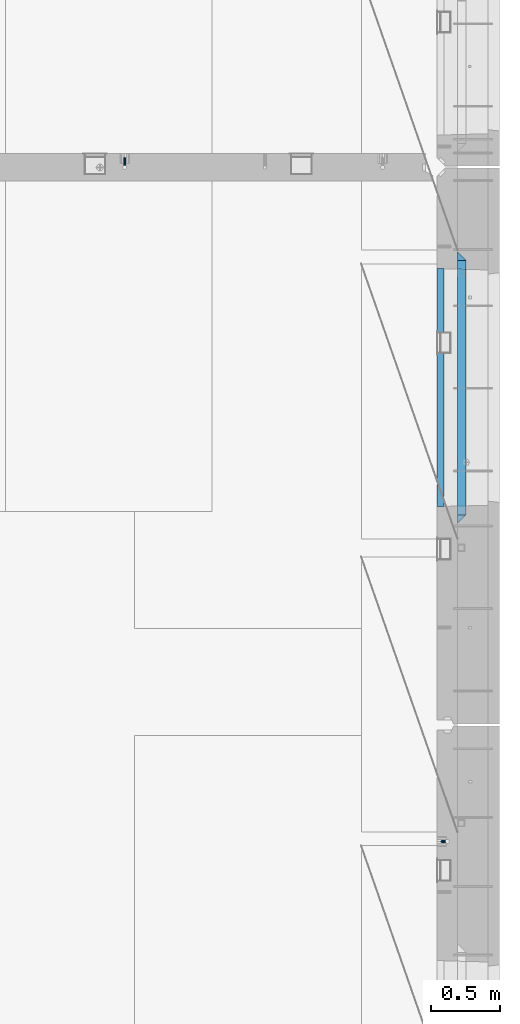
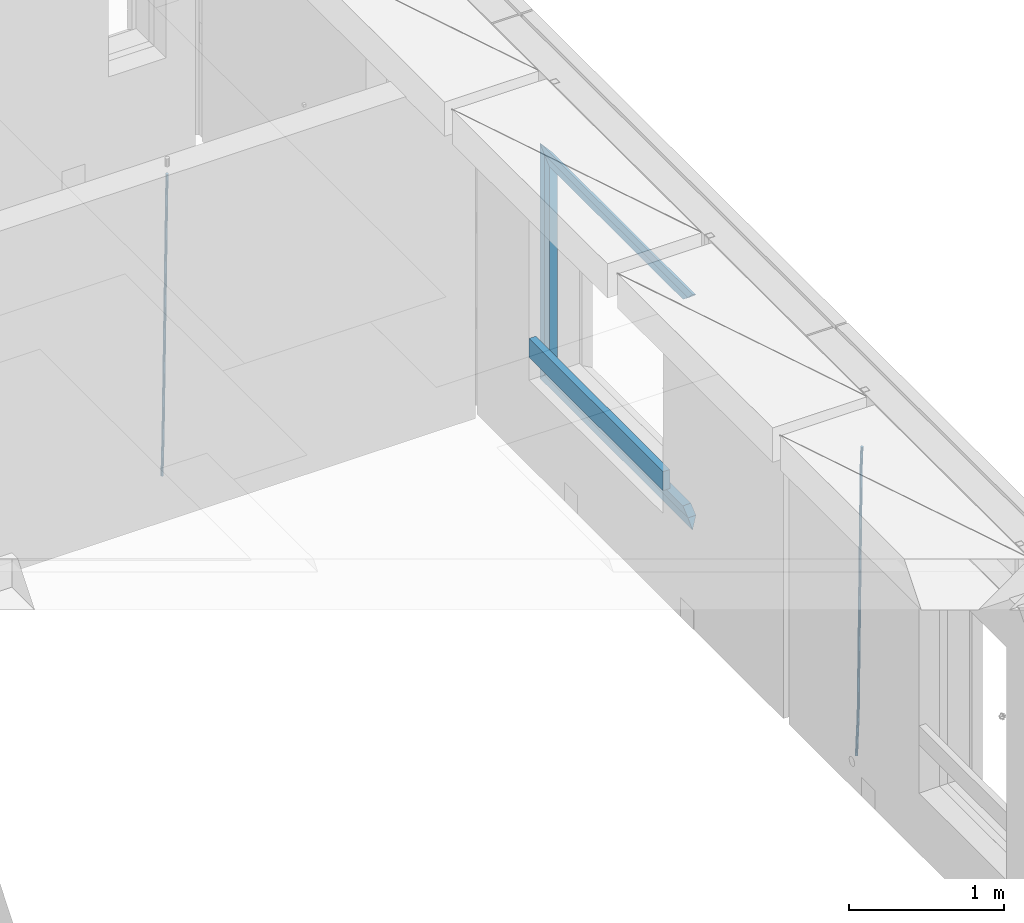
# One storey, part 131 of 352: 9 beams, 3 elements without a shape of their own.
"""IFC2X3 building model written with IfcOpenShell, lengths in millimetres."""

import ifcopenshell
import ifcopenshell.guid

model = None  # the IFC model being written
_history = None  # IfcOwnerHistory: only IFC2X3 demands one
_inside = {}  # id of a spatial element -> (the spatial element, [elements in it])
_under = {}  # id of a project, library or spatial element -> (it, [spatial elements below it])
_declared = {}  # id of a project -> (the project, [libraries it declares])
_typed = {}  # id of a type object -> (the type object, [elements of that type])
_made_of = {}  # id of a material, layer set ... -> (it, [elements and type objects made of it])


def new_model(schema):
    """Start an empty IFC model of exactly this schema.

    Asked for "IFC4X3", IfcOpenShell would pick the latest addendum, in which some entities
    have other attributes; the version numbers below select the first issue.
    IFC2X3 requires an IfcOwnerHistory on every rooted entity: one is made here for all.
    """
    global model, _history
    if schema == "IFC4X3":
        model = ifcopenshell.file(schema_version=(4, 3, 0, 0))
    else:
        model = ifcopenshell.file(schema=schema)
    _inside.clear()
    _under.clear()
    _declared.clear()
    _typed.clear()
    _made_of.clear()
    _history = None
    if model.schema == "IFC2X3":
        org = make("IfcOrganization", Name="unknown")
        user = make(
            "IfcPersonAndOrganization",
            ThePerson=make("IfcPerson", FamilyName="unknown"),
            TheOrganization=org,
        )
        app = make(
            "IfcApplication",
            ApplicationDeveloper=org,
            Version="unknown",
            ApplicationFullName="unknown",
            ApplicationIdentifier="unknown",
        )
        _history = make(
            "IfcOwnerHistory",
            OwningUser=user,
            OwningApplication=app,
            ChangeAction="ADDED",
            CreationDate=0,
        )
    return model


def make(cls, **values):
    """One entity of the class cls with the attributes given. An attribute that is None is left unset."""
    return model.create_entity(
        cls, **{name: value for name, value in values.items() if value is not None}
    )


def rooted(cls, **values):
    """An entity with a GlobalId (a new one), such as an element, a storey or a relation."""
    return make(cls, GlobalId=ifcopenshell.guid.new(), OwnerHistory=_history, **values)


def si_unit(unit_type, name, prefix=None):
    """IfcSIUnit, for example si_unit("LENGTHUNIT", "METRE", prefix="MILLI")."""
    return make("IfcSIUnit", UnitType=unit_type, Prefix=prefix, Name=name)


def assignment(units):
    """IfcUnitAssignment: the units of a project."""
    return None if units is None else make("IfcUnitAssignment", Units=units)


def point(xyz):
    """IfcCartesianPoint."""
    return None if xyz is None else make("IfcCartesianPoint", Coordinates=xyz)


def direction(xyz):
    """IfcDirection."""
    return None if xyz is None else make("IfcDirection", DirectionRatios=xyz)


def frame(location, z_axis=None, x_axis=None):
    """IfcAxis2Placement3D, a coordinate frame: its origin and axes. An axis left out is left unset."""
    return make(
        "IfcAxis2Placement3D",
        Location=point(location),
        Axis=direction(z_axis),
        RefDirection=direction(x_axis),
    )


def origin_with_axes():
    """The frame at (0, 0, 0) with the z axis (0, 0, 1) and the x axis (1, 0, 0) written out."""
    return frame((0.0, 0.0, 0.0), z_axis=(0.0, 0.0, 1.0), x_axis=(1.0, 0.0, 0.0))


def place(relative_to, where):
    """IfcLocalPlacement: puts the frame where relative to a parent placement (None: the world)."""
    return make(
        "IfcLocalPlacement", PlacementRelTo=relative_to, RelativePlacement=where
    )


def context(
    kind, dimensions, precision=None, world=None, true_north=None, identifier=None
):
    """IfcGeometricRepresentationContext, for example the 3D "Model" context."""
    return make(
        "IfcGeometricRepresentationContext",
        ContextIdentifier=identifier,
        ContextType=kind,
        CoordinateSpaceDimension=dimensions,
        Precision=precision,
        WorldCoordinateSystem=world,
        TrueNorth=true_north,
    )


def subcontext(parent, identifier, kind, view, scale=None):
    """IfcGeometricRepresentationSubContext, for example "Body" below "Model"."""
    return make(
        "IfcGeometricRepresentationSubContext",
        ContextIdentifier=identifier,
        ContextType=kind,
        ParentContext=parent,
        TargetScale=scale,
        TargetView=view,
    )


def project(units=None, contexts=None):
    """IfcProject with its units and contexts."""
    return rooted(
        "IfcProject",
        Name="project",
        RepresentationContexts=contexts,
        UnitsInContext=assignment(units),
    )


def spatial(cls, under=None, at=None, **own):
    """A site, building, storey or space (cls), placed at a placement, below another one or the project."""
    s = rooted(cls, ObjectPlacement=at, **own)
    if under is not None:
        _under.setdefault(under.id(), (under, []))[1].append(s)
    return s


def faces_of(points, faces, orient=None, outer=None):
    """IfcFace entities. A face is a list of loops; a loop is a list of indices into points, from 0.

    orient and outer hold one flag for each loop. By default every Orientation is true, the
    first loop of a face is its IfcFaceOuterBound and the others are IfcFaceBound.
    """
    made = []
    for i, loops in enumerate(faces):
        bounds = []
        for j, loop in enumerate(loops):
            is_outer = j == 0 if outer is None else outer[i][j]
            bounds.append(
                make(
                    "IfcFaceOuterBound" if is_outer else "IfcFaceBound",
                    Bound=make("IfcPolyLoop", Polygon=[points[k] for k in loop]),
                    Orientation=True if orient is None else orient[i][j],
                )
            )
        made.append(make("IfcFace", Bounds=bounds))
    return made


def faceted_brep(points, faces, orient=None, outer=None, voids=None):
    """IfcFacetedBrep: a solid bounded by flat faces; with voids (closed shells), ...WithVoids."""
    shared = [point(p) for p in points]
    hull = make("IfcClosedShell", CfsFaces=faces_of(shared, faces, orient, outer))
    if voids is None:
        return make("IfcFacetedBrep", Outer=hull)
    return make(
        "IfcFacetedBrepWithVoids",
        Outer=hull,
        Voids=[
            make(cls, CfsFaces=faces_of(shared, fs, o, b)) for cls, fs, o, b in voids
        ],
    )


def shape(context_of_items, identifier, shape_type, items):
    """IfcShapeRepresentation: the items that make up one representation, for example the "Body"."""
    return make(
        "IfcShapeRepresentation",
        ContextOfItems=context_of_items,
        RepresentationIdentifier=identifier,
        RepresentationType=shape_type,
        Items=items,
    )


def material(Name=None, Category=None):
    """IfcMaterial."""
    return make("IfcMaterial", Name=Name, Category=Category)


def made_of(thing, what):
    """Note that an element or type object is made of a material, layer set ...; save() writes the relation."""
    if what is not None:
        _made_of.setdefault(what.id(), (what, []))[1].append(thing)
    return thing


def type_object(cls, material=None, **own):
    """A type object (cls), such as IfcWallType, which elements share."""
    return made_of(rooted(cls, **own), material)


def element(
    cls,
    number,
    at=None,
    inside=None,
    cuts=None,
    type_object=None,
    material=None,
    context=None,
    identifier="Body",
    shape_type=None,
    held_by="IfcProductDefinitionShape",
    body=None,
    shapes=None,
    **own,
):
    """One element of the class cls, such as IfcWall. Its Tag is "e" and its number.

    at: its placement. inside: the storey or other place that contains it. cuts: it is an
    opening in that element (IfcRelVoidsElement). A single representation is given by context,
    identifier, shape_type and body (its items); several are given by shapes. held_by: the class
    of the entity that holds the representations. save() writes the other relations.
    """
    e = rooted(cls, Tag="e%d" % number, ObjectPlacement=at, **own)
    if body is not None:
        shapes = [shape(context, identifier, shape_type, body)]
    if shapes is not None:
        e.Representation = make(held_by, Representations=shapes)
    if inside is not None:
        _inside.setdefault(inside.id(), (inside, []))[1].append(e)
    if cuts is not None:
        rooted(
            "IfcRelVoidsElement", RelatingBuildingElement=cuts, RelatedOpeningElement=e
        )
    if type_object is not None:
        _typed.setdefault(type_object.id(), (type_object, []))[1].append(e)
    return made_of(e, material)


def aggregate(whole, parts):
    """IfcRelAggregates: a whole, such as a stair, and the parts it consists of."""
    return rooted("IfcRelAggregates", RelatingObject=whole, RelatedObjects=parts)


def save(model, path):
    """Write the relations noted so far, then the file.

    IfcRelAggregates (storeys below a building ...), IfcRelContainedInSpatialStructure (elements
    in a storey), IfcRelDefinesByType, IfcRelAssociatesMaterial and IfcRelDeclares: one each for
    every whole, place, type object, material and project.
    """
    for whole, parts in _under.values():
        aggregate(whole, parts)
    for where, things in _inside.values():
        rooted(
            "IfcRelContainedInSpatialStructure",
            RelatedElements=things,
            RelatingStructure=where,
        )
    for kind, things in _typed.values():
        rooted("IfcRelDefinesByType", RelatedObjects=things, RelatingType=kind)
    for what, things in _made_of.values():
        rooted("IfcRelAssociatesMaterial", RelatedObjects=things, RelatingMaterial=what)
    for by, libraries in _declared.values():
        rooted("IfcRelDeclares", RelatingContext=by, RelatedDefinitions=libraries)
    model.write(path)


model = new_model("IFC2X3")

# Units and contexts
model_context = context("Model", 3, precision=1e-05, world=origin_with_axes())
body_context = subcontext(model_context, "Body", "Model", "MODEL_VIEW")
ifc_project = project(units=[si_unit("LENGTHUNIT", "METRE", prefix="MILLI"), si_unit("AREAUNIT", "SQUARE_METRE"), si_unit("VOLUMEUNIT", "CUBIC_METRE"), si_unit("MASSUNIT", "GRAM", prefix="KILO"), si_unit("TIMEUNIT", "SECOND"), si_unit("PLANEANGLEUNIT", "RADIAN"), si_unit("SOLIDANGLEUNIT", "STERADIAN"), si_unit("THERMODYNAMICTEMPERATUREUNIT", "DEGREE_CELSIUS"), si_unit("LUMINOUSINTENSITYUNIT", "LUMEN")], contexts=[model_context])

# Site, building, storey
site_placement = place(None, origin_with_axes())
site = spatial("IfcSite", under=ifc_project, at=site_placement, CompositionType="ELEMENT")
building_placement = place(site_placement, origin_with_axes())
building = spatial("IfcBuilding", under=site, at=building_placement, CompositionType="ELEMENT")
storey_placement = place(building_placement, origin_with_axes())
storey = spatial("IfcBuildingStorey", under=building, at=storey_placement, Name="6", CompositionType="ELEMENT", Elevation=0.0)

# Assembly, beam
assembly_1_placement = place(storey_placement, origin_with_axes())
assembly_1 = element("IfcElementAssembly", 1, at=assembly_1_placement, inside=storey, AssemblyPlace="NOTDEFINED", PredefinedType="REINFORCEMENT_UNIT")
ifc_material_1 = material()
beam_type_1 = type_object("IfcBeamType", Name="D20", PredefinedType="NOTDEFINED")
beam_1_placement = place(assembly_1_placement, frame((32639.9999999961, 17044.9997581385, 96990.0), z_axis=(0.00020576299992186, -0.999642804629538, -0.0267249099901004), x_axis=(-4.30000201928125e-08, -0.0267249099948059, 0.999642825806181)))
beam_1 = element("IfcBeam", 2, at=beam_1_placement, type_object=beam_type_1, material=ifc_material_1, Name="JM20", ObjectType="D20", context=body_context, shape_type="Brep", body=[
    faceted_brep([(0.0, -10.0, 0.0), (-4.19531716033816e-08, -7.07106781186667, -7.07106781187031), (60.4266690400545, -7.0710677960451, -7.07106780570757), (60.4266690441291, -9.99999998418934, 6.15546014159918e-09), (0.0, 0.0, -10.0), (60.426669036824, 1.58106558956206e-08, -9.99999999384454), (4.196772351861e-08, 7.07106781186303, -7.07106781186667), (60.4266690363438, 7.07106782768096, -7.07106780570757), (0.0, 10.0, 0.0), (60.4266690388904, 10.0000000158179, 6.15182216279209e-09), (4.196772351861e-08, 7.07106781185939, 7.07106781185939), (60.4266690429649, 7.07106782768096, 7.07106781802577), (0.0, 0.0, 10.0), (60.4266690461809, 1.58179318532348e-08, 10.0000000061555), (-4.19531716033816e-08, -7.07106781187031, 7.07106781185939), (60.4266690466611, -7.07106779605238, 7.07106781802213), (61.0378400410118, -7.07106779588503, -7.07106780564936), (60.991799419251, -9.99999998403655, 6.21366780251265e-09), (61.0569027789461, 1.5985278878361e-08, -9.99999999378269), (61.0378209396877, 7.07106782784831, -7.07106780564936), (60.9917724058905, 10.0000000159635, 6.21366780251265e-09), (60.9457317841297, 7.07106782781193, 7.0710678180767), (60.9266690461809, 1.59488990902901e-08, 10.0000000062028), (60.9457508854539, -7.07106779591413, 7.0710678180767), (61.6489592143771, -7.07106614513759, -7.06310863441468), (61.5568818710308, -9.9999984576425, 0.00735959856683621), (61.6870830769039, 1.71821739058942e-06, -9.99179257185824), (61.6489210170112, 7.07106947854481, -7.06310888312146), (61.556827851804, 10.0000015422847, 0.00735924683976918), (61.4647505084577, 7.07106922979438, 7.07782747982128), (61.4266266459163, 1.36643211590126e-06, 10.0065114172685), (61.464788705809, -7.07106639389531, 7.07782772852806), (176.543135720174, -7.07075579406956, -5.56673531796696), (176.451058376813, -9.99968810657447, 1.50373291501455), (176.581259582701, 0.000312069292704109, -8.49541925541052), (176.543097522794, 7.07137982961285, -5.56673556667374), (176.451004357587, 10.00031189336, 1.50373256329476), (176.35892701424, 7.07137958085514, 8.57420079627263), (176.320803151699, 0.000311717507429421, 11.5028847337162), (176.358965211621, -7.07075604281999, 8.57420104497578), (177.098753836006, -7.07075429323595, -5.55949898843028), (176.98362511232, -9.99968666800123, 1.510669025065), (177.146421932586, 0.000313595905026887, -8.48805862247536), (177.098706077581, 7.07138133041735, -5.55949936166144), (176.983557571715, 10.0003133318824, 1.51066849724157), (176.868428848029, 7.07138095712435, 8.58083651073321), (176.820760751449, 0.000313067976094317, 11.5093961447819), (176.868476606425, -7.07075466652896, 8.58083688396073), (177.654312950661, -7.07075204110879, -5.54863964998367), (177.516135294456, -9.99968450931192, 1.52107783331303), (177.711524267797, 0.000315886711177882, -8.47701274570863), (177.654255632195, 7.07138358250813, -5.54864021007961), (177.516054233929, 10.0003154905207, 1.5210770412159), (177.377876577739, 7.0713830223176, 8.59079452451624), (177.320665260588, 0.000315094497636892, 11.5191676202448), (177.377933896176, -7.07075260129932, 8.59079508461218), (299.499456785634, -7.07025810522464, -3.16697112782276), (299.361279129444, -9.99919057342777, 3.90274635547394), (299.556668102785, 0.000809822595329024, -6.09534422354773), (299.499399467197, 7.07187751838501, -3.1669716879187), (299.361198068917, 10.0008094264049, 3.90274556338045), (299.223020412712, 7.07187695819448, 10.9724630466735), (299.165809095575, 0.000809030381788034, 13.9008361423985), (299.223077731163, -7.07025866542244, 10.9724636067695), (300.03174732349, -7.07025594743027, -3.15656661289177), (299.971788958996, -9.99918809853989, 3.91467979818117), (300.056572611924, 0.000811849109595641, -6.08557274808481), (300.031722507032, 7.07187967631762, -3.15656653768019), (299.971753863239, 10.0008119014747, 3.91467990454839), (299.91179549876, 7.07187975035777, 10.9859263156177), (299.886970210311, 0.000811953817901667, 13.9149324508144), (299.911820315203, -7.0702558733974, 10.9859262404061), (300.564137759997, -7.07025623699155, -3.15794273276697), (300.582413367199, -9.99918843065097, 3.91310145956595), (300.556570941641, 0.000811577163403854, -6.0868651410201), (300.564145451674, 7.07187938674906, -3.15794274158179), (300.582424244858, 10.0008115693345, 3.91310144710224), (300.600699852032, 7.07187937566778, 10.9841456394352), (300.608266670402, 0.000811561512819026, 13.9130680476919), (300.600692160384, -7.07025624805829, 10.98414564825), (2294.16589219622, -7.0713405251372, -8.31099358700158), (2294.1841678034, -10.0002727187966, -1.23994939466866), (2294.15832537785, -0.000272710982244462, -11.2399159952547), (2294.16589988787, 7.07079509858886, -8.31099359582004), (2294.18417868105, 9.99972728118883, -1.23994940713601), (2294.20245428824, 7.07079508752213, 5.83109478519327), (2294.2100211066, -0.00027272663282929, 8.76001719345368), (2294.20244659658, -7.07134053620393, 5.83109479401173), (2294.7782683276, -7.07134085819416, -8.31257645345977), (2294.72126025338, -10.000273010919, -1.24133766827799), (2294.84007459224, -0.000273081772320438, -11.2416781768807), (2294.87047377572, 7.07079471537872, -8.31281477453012), (2294.85165844864, 9.9997269181622, -1.24167470516841), (2294.7946503744, 7.07079476544459, 5.82956408001337), (2294.73284410976, -0.000273010977252852, 8.75866580342336), (2294.7024449263, -7.07134080815013, 5.82980240107645), (2295.39054023061, -7.0793250091956, -8.30442771922026), (2295.25826128852, -10.0072756143927, -1.23419071494573), (2295.52170777075, -0.00916171800054144, -11.2326063125765), (2295.57492774284, 7.06160849139269, -8.30343918807193), (2295.51902460904, 9.99102432676591, -1.23279272078435), (2295.38674566693, 7.06307372157607, 5.83744428349019), (2295.25557812679, -0.0070895696117077, 8.76562287684646), (2295.20235815471, -7.07785977901949, 5.83645575234186), (2317.1947101649, -7.36365585014573, -8.01423575520312), (2317.06243122277, -10.2916064553428, -0.94399875092131), (2317.32587770502, -0.293492558957951, -10.9424143485521), (2317.37909767711, 6.77727765044983, -8.01324722405116), (2317.32319454331, 9.70669348581578, -0.942600756767206), (2317.1909156012, 6.77874288063322, 6.12763624751096), (2317.05974806109, -0.291420410569117, 9.0558148408636), (2317.00652808898, -7.36219061996962, 6.12664771636264), (2317.83015404257, -7.37194216843636, -8.00577862486898), (2317.72252095213, -10.300214160583, -0.935213608652703), (2317.90419832576, -0.301033978277701, -10.9347174723516), (2317.90127966482, 6.77046829039318, -8.00629749759901), (2317.82310777172, 9.70017451494641, -0.935947405505431), (2317.71547468127, 6.77190252279979, 6.13461761071085), (2317.64143039809, -0.29900566735887, 9.06355645819713), (2317.64434905903, -7.37050793602975, 6.13513648344451), (2318.46565174212, -7.3700661537805, -7.99751648408346), (2318.38266643914, -10.2982456018653, -0.926623872735945), (2318.48256818345, -0.299336209594912, -10.9272153854981), (2318.42350634121, 6.77200652527245, -7.99954269419686), (2318.32306384158, 9.70166538090416, -0.929489366557391), (2318.2400785386, 6.77348593281204, 6.14140324480104), (2318.22316209726, -0.297244011366274, 9.07110214621207), (2318.2822239395, -7.36858674623363, 6.1434294549108), (2418.48643733139, -7.07180401323421, -6.70013846199799), (2418.4034520284, -9.99998346132634, 0.370754149349523), (2418.5033537727, -0.00107406904135132, -9.62983736341266), (2418.44429193046, 7.07026866581873, -6.70216467211139), (2418.34384943081, 9.99992752145772, 0.367888655531715), (2418.26086412782, 7.0717480733656, 7.43878126688651), (2418.24394768651, 0.00101812917273492, 10.3684801682975), (2418.30300952874, -7.07032460568735, 7.44080747699627)], [[[0, 1, 2, 3]], [[1, 4, 5, 2]], [[4, 6, 7, 5]], [[6, 8, 9, 7]], [[8, 10, 11, 9]], [[10, 12, 13, 11]], [[12, 14, 15, 13]], [[14, 0, 3, 15]], [[14, 12, 10, 8, 6, 4, 1, 0]], [[3, 2, 16, 17]], [[2, 5, 18, 16]], [[5, 7, 19, 18]], [[7, 9, 20, 19]], [[9, 11, 21, 20]], [[11, 13, 22, 21]], [[13, 15, 23, 22]], [[15, 3, 17, 23]], [[17, 16, 24, 25]], [[16, 18, 26, 24]], [[18, 19, 27, 26]], [[19, 20, 28, 27]], [[20, 21, 29, 28]], [[21, 22, 30, 29]], [[22, 23, 31, 30]], [[23, 17, 25, 31]], [[25, 24, 32, 33]], [[24, 26, 34, 32]], [[26, 27, 35, 34]], [[27, 28, 36, 35]], [[28, 29, 37, 36]], [[29, 30, 38, 37]], [[30, 31, 39, 38]], [[31, 25, 33, 39]], [[33, 32, 40, 41]], [[32, 34, 42, 40]], [[34, 35, 43, 42]], [[35, 36, 44, 43]], [[36, 37, 45, 44]], [[37, 38, 46, 45]], [[38, 39, 47, 46]], [[39, 33, 41, 47]], [[41, 40, 48, 49]], [[40, 42, 50, 48]], [[42, 43, 51, 50]], [[43, 44, 52, 51]], [[44, 45, 53, 52]], [[45, 46, 54, 53]], [[46, 47, 55, 54]], [[47, 41, 49, 55]], [[49, 48, 56, 57]], [[48, 50, 58, 56]], [[50, 51, 59, 58]], [[51, 52, 60, 59]], [[52, 53, 61, 60]], [[53, 54, 62, 61]], [[54, 55, 63, 62]], [[55, 49, 57, 63]], [[57, 56, 64, 65]], [[56, 58, 66, 64]], [[58, 59, 67, 66]], [[59, 60, 68, 67]], [[60, 61, 69, 68]], [[61, 62, 70, 69]], [[62, 63, 71, 70]], [[63, 57, 65, 71]], [[65, 64, 72, 73]], [[64, 66, 74, 72]], [[66, 67, 75, 74]], [[67, 68, 76, 75]], [[68, 69, 77, 76]], [[69, 70, 78, 77]], [[70, 71, 79, 78]], [[71, 65, 73, 79]], [[73, 72, 80, 81]], [[72, 74, 82, 80]], [[74, 75, 83, 82]], [[75, 76, 84, 83]], [[76, 77, 85, 84]], [[77, 78, 86, 85]], [[78, 79, 87, 86]], [[79, 73, 81, 87]], [[81, 80, 88, 89]], [[80, 82, 90, 88]], [[82, 83, 91, 90]], [[83, 84, 92, 91]], [[84, 85, 93, 92]], [[85, 86, 94, 93]], [[86, 87, 95, 94]], [[87, 81, 89, 95]], [[89, 88, 96, 97]], [[88, 90, 98, 96]], [[90, 91, 99, 98]], [[91, 92, 100, 99]], [[92, 93, 101, 100]], [[93, 94, 102, 101]], [[94, 95, 103, 102]], [[95, 89, 97, 103]], [[97, 96, 104, 105]], [[96, 98, 106, 104]], [[98, 99, 107, 106]], [[99, 100, 108, 107]], [[100, 101, 109, 108]], [[101, 102, 110, 109]], [[102, 103, 111, 110]], [[103, 97, 105, 111]], [[105, 104, 112, 113]], [[104, 106, 114, 112]], [[106, 107, 115, 114]], [[107, 108, 116, 115]], [[108, 109, 117, 116]], [[109, 110, 118, 117]], [[110, 111, 119, 118]], [[111, 105, 113, 119]], [[113, 112, 120, 121]], [[112, 114, 122, 120]], [[114, 115, 123, 122]], [[115, 116, 124, 123]], [[116, 117, 125, 124]], [[117, 118, 126, 125]], [[118, 119, 127, 126]], [[119, 113, 121, 127]], [[121, 120, 128, 129]], [[120, 122, 130, 128]], [[122, 123, 131, 130]], [[123, 124, 132, 131]], [[124, 125, 133, 132]], [[125, 126, 134, 133]], [[126, 127, 135, 134]], [[127, 121, 129, 135]], [[130, 131, 132, 133, 134, 135, 129, 128]]]),
])
aggregate(assembly_1, [beam_1])

assembly_2_placement = place(storey_placement, origin_with_axes())
assembly_2 = element("IfcElementAssembly", 3, at=assembly_2_placement, inside=storey, AssemblyPlace="NOTDEFINED", PredefinedType="REINFORCEMENT_UNIT")
beam_2_placement = place(assembly_2_placement, frame((34944.9999977209, 12080.9402860984, 96990.0), z_axis=(0.999642804629538, 0.000205762999925497, -0.0267249099901003), x_axis=(0.0267249109941254, -4.30000210532798e-08, 0.999642825779465)))
beam_2 = element("IfcBeam", 4, at=beam_2_placement, type_object=beam_type_1, material=ifc_material_1, Name="JM20", ObjectType="D20", context=body_context, shape_type="Brep", body=[
    faceted_brep([(0.0, -10.0, 0.0), (-4.19531716033816e-08, -7.07106781186667, -7.07106781187031), (60.4266690400545, -7.0710677960451, -7.07106780570757), (60.4266690441291, -9.99999998418934, 6.15546014159918e-09), (0.0, 0.0, -10.0), (60.426669036824, 1.58106558956206e-08, -9.99999999384454), (4.196772351861e-08, 7.07106781186303, -7.07106781186667), (60.4266690363438, 7.07106782768096, -7.07106780570757), (0.0, 10.0, 0.0), (60.4266690388904, 10.0000000158179, 6.15182216279209e-09), (4.196772351861e-08, 7.07106781185939, 7.07106781185939), (60.4266690429649, 7.07106782768096, 7.07106781802577), (0.0, 0.0, 10.0), (60.4266690461809, 1.58179318532348e-08, 10.0000000061555), (-4.19531716033816e-08, -7.07106781187031, 7.07106781185939), (60.4266690466611, -7.07106779605238, 7.07106781802213), (61.0378400410118, -7.07106779588503, -7.07106780564936), (60.991799419251, -9.99999998403655, 6.21366780251265e-09), (61.0569027789461, 1.5985278878361e-08, -9.99999999378269), (61.0378209396877, 7.07106782784831, -7.07106780564936), (60.9917724058905, 10.0000000159635, 6.21366780251265e-09), (60.9457317841297, 7.07106782781193, 7.0710678180767), (60.9266690461809, 1.59488990902901e-08, 10.0000000062028), (60.9457508854539, -7.07106779591413, 7.0710678180767), (61.6489592143771, -7.07106614513759, -7.06310863441468), (61.5568818710308, -9.9999984576425, 0.00735959856683621), (61.6870830769039, 1.71821739058942e-06, -9.99179257185824), (61.6489210170112, 7.07106947854481, -7.06310888312146), (61.556827851804, 10.0000015422847, 0.00735924683976918), (61.4647505084577, 7.07106922979438, 7.07782747982128), (61.4266266459163, 1.36643211590126e-06, 10.0065114172685), (61.464788705809, -7.07106639389531, 7.07782772852806), (176.543135720174, -7.07075579406956, -5.56673531796696), (176.451058376813, -9.99968810657447, 1.50373291501455), (176.581259582701, 0.000312069292704109, -8.49541925541052), (176.543097522794, 7.07137982961285, -5.56673556667374), (176.451004357587, 10.00031189336, 1.50373256329476), (176.35892701424, 7.07137958085514, 8.57420079627263), (176.320803151699, 0.000311717507429421, 11.5028847337162), (176.358965211621, -7.07075604281999, 8.57420104497578), (177.098753836006, -7.07075429323595, -5.55949898843028), (176.98362511232, -9.99968666800123, 1.510669025065), (177.146421932586, 0.000313595905026887, -8.48805862247536), (177.098706077581, 7.07138133041735, -5.55949936166144), (176.983557571715, 10.0003133318824, 1.51066849724157), (176.868428848029, 7.07138095712435, 8.58083651073321), (176.820760751449, 0.000313067976094317, 11.5093961447819), (176.868476606425, -7.07075466652896, 8.58083688396073), (177.654312950661, -7.07075204110879, -5.54863964998367), (177.516135294456, -9.99968450931192, 1.52107783331303), (177.711524267797, 0.000315886711177882, -8.47701274570863), (177.654255632195, 7.07138358250813, -5.54864021007961), (177.516054233929, 10.0003154905207, 1.5210770412159), (177.377876577739, 7.0713830223176, 8.59079452451624), (177.320665260588, 0.000315094497636892, 11.5191676202448), (177.377933896176, -7.07075260129932, 8.59079508461218), (299.436796249574, -7.07025836271714, -3.1681962331204), (299.298618593355, -9.99919083092027, 3.90152125031091), (299.494007566798, 0.000809565110102994, -6.09656932889993), (299.436738931283, 7.07187726089978, -3.16819679320906), (299.298537533061, 10.0008091689197, 3.90152045822106), (299.160359876842, 7.07187670072017, 10.9712379416487), (299.103148559603, 0.000808772889286047, 13.8996110374392), (299.160417195119, -7.07025892290039, 10.9712385017483), (299.98743051647, -7.07025613056248, -3.15743315966392), (299.971788958996, -9.99918809853989, 3.91467979818117), (299.993912075952, 0.000811591617093654, -6.08679785393178), (299.987423933868, 7.07187949325817, -3.1574327280432), (299.971753863239, 10.0008119014747, 3.91467990454839), (299.95611230444, 7.07187992653053, 10.9867922621015), (299.949630744944, 0.000812204350950196, 13.9161569563694), (299.956118887014, -7.07025569729012, 10.9867918304735), (300.538107039494, -7.07025785017686, -3.16575821840888), (300.644985195438, -9.99919020432935, 3.90450175465594), (300.493854948218, 0.000810030429420294, -6.09435592770024), (300.538151196495, 7.071877773491, -3.16575855385963), (300.645047642858, 10.0008097955724, 3.90450128024895), (300.751925798773, 7.07187744142357, 10.9747612533101), (300.796177890064, 0.000809560813650023, 13.9033589625978), (300.751881641787, -7.07025818224065, 10.9747615887682), (2293.36490490142, -7.07648090940347, -33.2930642912361), (2293.47178305736, -10.0054132635523, -26.2228043181785), (2293.32065281013, -0.00541302880083094, -36.2216620005347), (2293.36494905842, 7.06565471425711, -33.2930646266868), (2293.47184550477, 9.99458673634581, -26.2228047925819), (2293.57872366071, 7.06565438219332, -19.1525448195243), (2293.62297575199, -0.00541349841296324, -16.2239471102366), (2293.57867950371, -7.0764812414709, -19.1525444840736), (2294.0658245362, -7.07648309818615, -33.3036607065333), (2294.05312277409, -10.0054150789219, -26.2315929392535), (2294.10928714235, -0.00541549149056664, -36.2335844756526), (2294.15805078732, 7.06565223761572, -33.3050546393533), (2294.18355038921, 9.99458451388637, -26.2335642579346), (2294.17084862708, 7.06565253314329, -19.1614964906439), (2294.12738602093, -0.00541507354500936, -16.2315727215355), (2294.07862237596, -7.07648280265857, -19.1601025578348), (2294.76670261032, -7.08562269121467, -33.294332712383), (2294.63442802057, -10.0129954178956, -26.2238563411993), (2294.89787471293, -0.0156988342423574, -36.2230891548279), (2294.95110548967, 7.05531064255774, -33.2944998654275), (2294.89521307347, 9.98530428734011, -26.2240927312887), (2294.76293848372, 7.0579315606592, -19.1536163601049), (2294.63176638114, -0.0119922963167483, -16.2248599176673), (2294.57853560438, -7.08300177311321, -19.1534492070678), (2316.52657204497, -7.36937582653991, -33.0047303660212), (2316.39429745522, -10.2967485532172, -25.9342539948302), (2316.65774414754, -0.299451969567599, -35.9334868084661), (2316.7109749243, 6.7715575072325, -33.0048975190657), (2316.65508250811, 9.70155115201487, -25.9344903849269), (2316.52280791836, 6.7741784253376, -18.8640140137468), (2316.39163581574, -0.295745431634714, -15.9352575713092), (2316.33840503903, -7.36675490843481, -18.863846860706), (2317.16202064224, -7.37766220584308, -32.9962731735213), (2317.05438744847, -10.3053562613532, -25.9254688497131), (2317.23607125619, -0.306993473008333, -35.925789846493), (2317.23316144495, 6.76474808850253, -32.9979477328052), (2317.15499573652, 9.6950321815566, -25.9278370341635), (2317.04736254275, 6.7673381260538, -18.8570327103698), (2316.97331192881, -0.303330606784584, -15.9275160373909), (2316.97622174003, -7.37507216829545, -18.8553581510787), (2317.79752306276, -7.37578610372293, -32.9880110666527), (2317.71453320107, -10.3033876998124, -25.9168792378296), (2317.81444760226, -0.305295583297266, -35.918287695793), (2317.75539265381, 6.76628640723357, -32.9911928173897), (2317.65495180529, 9.69652304524061, -25.9213789128698), (2317.5719619436, 6.76892144914746, -18.8502470840467), (2317.55503740412, -0.301569071270933, -15.9199704549137), (2317.61409235255, -7.3731510618054, -18.847065333317), (2417.8183084176, -7.07752398473531, -31.6906369377139), (2417.73531855589, -10.0051255808248, -24.6195051088798), (2417.83523295709, -0.007033464313281, -34.6209135668432), (2417.77617800863, 7.06454852621755, -31.6938186884508), (2417.67573716014, 9.99478516423187, -24.6240047839383), (2417.59274729842, 7.06718356813872, -17.5528729551006), (2417.57582275895, -0.00330695228694822, -14.6225963259749), (2417.6348777074, -7.07488894281778, -17.5496912043673)], [[[0, 1, 2, 3]], [[1, 4, 5, 2]], [[4, 6, 7, 5]], [[6, 8, 9, 7]], [[8, 10, 11, 9]], [[10, 12, 13, 11]], [[12, 14, 15, 13]], [[14, 0, 3, 15]], [[14, 12, 10, 8, 6, 4, 1, 0]], [[3, 2, 16, 17]], [[2, 5, 18, 16]], [[5, 7, 19, 18]], [[7, 9, 20, 19]], [[9, 11, 21, 20]], [[11, 13, 22, 21]], [[13, 15, 23, 22]], [[15, 3, 17, 23]], [[17, 16, 24, 25]], [[16, 18, 26, 24]], [[18, 19, 27, 26]], [[19, 20, 28, 27]], [[20, 21, 29, 28]], [[21, 22, 30, 29]], [[22, 23, 31, 30]], [[23, 17, 25, 31]], [[25, 24, 32, 33]], [[24, 26, 34, 32]], [[26, 27, 35, 34]], [[27, 28, 36, 35]], [[28, 29, 37, 36]], [[29, 30, 38, 37]], [[30, 31, 39, 38]], [[31, 25, 33, 39]], [[33, 32, 40, 41]], [[32, 34, 42, 40]], [[34, 35, 43, 42]], [[35, 36, 44, 43]], [[36, 37, 45, 44]], [[37, 38, 46, 45]], [[38, 39, 47, 46]], [[39, 33, 41, 47]], [[41, 40, 48, 49]], [[40, 42, 50, 48]], [[42, 43, 51, 50]], [[43, 44, 52, 51]], [[44, 45, 53, 52]], [[45, 46, 54, 53]], [[46, 47, 55, 54]], [[47, 41, 49, 55]], [[49, 48, 56, 57]], [[48, 50, 58, 56]], [[50, 51, 59, 58]], [[51, 52, 60, 59]], [[52, 53, 61, 60]], [[53, 54, 62, 61]], [[54, 55, 63, 62]], [[55, 49, 57, 63]], [[57, 56, 64, 65]], [[56, 58, 66, 64]], [[58, 59, 67, 66]], [[59, 60, 68, 67]], [[60, 61, 69, 68]], [[61, 62, 70, 69]], [[62, 63, 71, 70]], [[63, 57, 65, 71]], [[65, 64, 72, 73]], [[64, 66, 74, 72]], [[66, 67, 75, 74]], [[67, 68, 76, 75]], [[68, 69, 77, 76]], [[69, 70, 78, 77]], [[70, 71, 79, 78]], [[71, 65, 73, 79]], [[73, 72, 80, 81]], [[72, 74, 82, 80]], [[74, 75, 83, 82]], [[75, 76, 84, 83]], [[76, 77, 85, 84]], [[77, 78, 86, 85]], [[78, 79, 87, 86]], [[79, 73, 81, 87]], [[81, 80, 88, 89]], [[80, 82, 90, 88]], [[82, 83, 91, 90]], [[83, 84, 92, 91]], [[84, 85, 93, 92]], [[85, 86, 94, 93]], [[86, 87, 95, 94]], [[87, 81, 89, 95]], [[89, 88, 96, 97]], [[88, 90, 98, 96]], [[90, 91, 99, 98]], [[91, 92, 100, 99]], [[92, 93, 101, 100]], [[93, 94, 102, 101]], [[94, 95, 103, 102]], [[95, 89, 97, 103]], [[97, 96, 104, 105]], [[96, 98, 106, 104]], [[98, 99, 107, 106]], [[99, 100, 108, 107]], [[100, 101, 109, 108]], [[101, 102, 110, 109]], [[102, 103, 111, 110]], [[103, 97, 105, 111]], [[105, 104, 112, 113]], [[104, 106, 114, 112]], [[106, 107, 115, 114]], [[107, 108, 116, 115]], [[108, 109, 117, 116]], [[109, 110, 118, 117]], [[110, 111, 119, 118]], [[111, 105, 113, 119]], [[113, 112, 120, 121]], [[112, 114, 122, 120]], [[114, 115, 123, 122]], [[115, 116, 124, 123]], [[116, 117, 125, 124]], [[117, 118, 126, 125]], [[118, 119, 127, 126]], [[119, 113, 121, 127]], [[121, 120, 128, 129]], [[120, 122, 130, 128]], [[122, 123, 131, 130]], [[123, 124, 132, 131]], [[124, 125, 133, 132]], [[125, 126, 134, 133]], [[126, 127, 135, 134]], [[127, 121, 129, 135]], [[130, 131, 132, 133, 134, 135, 129, 128]]]),
])
aggregate(assembly_2, [beam_2])

# Assembly, beams
assembly_3_placement = place(storey_placement, origin_with_axes())
assembly_3 = element("IfcElementAssembly", 5, at=assembly_3_placement, inside=storey, AssemblyPlace="NOTDEFINED", PredefinedType="REINFORCEMENT_UNIT")
ifc_material_2 = material(Name="TIMBER/T24")
beam_type_2 = type_object("IfcBeamType", PredefinedType="NOTDEFINED")
beam_3_placement = place(assembly_3_placement, frame((34935.0002758707, 14515.0011884524, 97685.0), z_axis=(0.0, 0.0, 1.0), x_axis=(0.0, 1.0, 0.0)))
beam_3 = element("IfcBeam", 6, at=beam_3_placement, type_object=beam_type_2, material=ifc_material_2, context=body_context, shape_type="Brep", body=[
    faceted_brep([(-3.63797880709171e-12, 24.9999999999964, -75.0), (-3.63797880709171e-12, 24.9999999999964, 75.0), (1730.0, 25.0, 75.0), (1730.0, 25.0, -75.0), (0.0, -25.0000000000073, 75.0), (1730.0, -25.0, 75.0), (0.0, -25.0000000000073, -75.0), (1730.0, -25.0, -75.0)], [[[0, 1, 2, 3]], [[1, 4, 5, 2]], [[4, 6, 7, 5]], [[6, 0, 3, 7]], [[5, 7, 3, 2]], [[6, 4, 1, 0]]]),
])
ifc_material_3 = material(Name="CONCRETE/C25/30")
beam_type_3 = type_object("IfcBeamType", PredefinedType="NOTDEFINED")
beam_4_placement = place(assembly_3_placement, frame((35090.0, 14394.9995850056, 99145.0), z_axis=(0.0, 0.0, -1.0), x_axis=(0.0, 1.0, 0.0)))
beam_4 = element("IfcBeam", 7, at=beam_4_placement, type_object=beam_type_3, material=ifc_material_3, Name="SK", context=body_context, shape_type="Brep", body=[
    faceted_brep([(60.0000000000073, 30.0, 30.0), (0.0, -30.0, -30.0), (60.0000000000073, -30.0, 30.0), (1910.00076293945, 30.0, 30.0), (1970.00076293945, -30.0, -30.0), (1910.00076293945, -30.0, 30.0)], [[[0, 1, 2]], [[1, 0, 3, 4]], [[2, 1, 4, 5]], [[0, 2, 5, 3]], [[4, 3, 5]]]),
])
beam_5_placement = place(assembly_3_placement, frame((35090.0, 14454.9995850056, 99085.0), z_axis=(0.0, 0.0, -1.0), x_axis=(0.0, 1.0, 0.0)))
beam_5 = element("IfcBeam", 8, at=beam_5_placement, type_object=beam_type_3, material=ifc_material_3, Name="SK", context=body_context, shape_type="Brep", body=[
    faceted_brep([(1785.9467088854, -30.0, 24.0540540540533), (1784.32508726378, 30.0, 25.6756756756804), (65.6764386151262, 30.0, 25.6756756756804), (64.0548169935064, -30.0, 24.0540540540533), (65.6764386151262, 30.0, 26.294090229203), (64.0548169935064, -30.0, 24.9041288395529), (0.0, 30.0, -30.0), (0.0, -30.0, -30.0), (1850.00076293945, 30.0, -30.0), (1850.00076293945, -30.0, -30.0), (1785.9467088854, -30.0, 24.9034748914128), (1784.32508726378, 30.0, 26.2934362810774)], [[[0, 1, 2, 3]], [[3, 2, 4, 5]], [[5, 4, 6, 7]], [[7, 6, 8, 9]], [[0, 3, 5, 7, 9, 10]], [[1, 0, 10, 11]], [[6, 4, 2, 1, 11, 8]], [[9, 8, 11, 10]]]),
])
beam_6_placement = place(assembly_3_placement, frame((35090.0, 16335.0003479451, 99175.0), z_axis=(0.0, -1.0, 0.0), x_axis=(0.0, 0.0, -1.0)))
beam_6 = element("IfcBeam", 9, at=beam_6_placement, type_object=beam_type_3, material=ifc_material_3, Name="SK", context=body_context, shape_type="Brep", body=[
    faceted_brep([(60.0000000000073, 30.0, 30.0), (0.0, -30.0, -30.0), (60.0000000000073, -30.0, 30.0), (1795.00000000001, 30.0, 30.0), (1855.0, -30.0, -30.0), (1795.00000000001, -30.0, 30.0)], [[[0, 1, 2]], [[3, 4, 1, 0]], [[4, 5, 2, 1]], [[5, 3, 0, 2]], [[5, 4, 3]]]),
])
beam_7_placement = place(assembly_3_placement, frame((35090.0, 16305.0003479451, 97410.0), z_axis=(0.0, 0.0, 1.0), x_axis=(0.0, -1.0, 0.0)))
beam_7 = element("IfcBeam", 10, at=beam_7_placement, type_object=beam_type_3, material=ifc_material_3, Name="SK", context=body_context, shape_type="Brep", body=[
    faceted_brep([(1785.94594594595, -30.0, 24.0540540540533), (1784.32432432433, 30.0, 25.6756756756804), (65.6756756756768, 30.0, 25.6756756756804), (64.0540540540533, -30.0, 24.0540540540533), (1785.94594594595, -30.0, 24.9041288395238), (1784.32432432433, 30.0, 26.2940902291739), (1850.00076293945, -30.0, -30.0), (1850.00076293945, 30.0, -30.0), (0.0, 30.0, -30.0), (65.6756756756768, 30.0, 26.293436281092), (64.0540540540533, -30.0, 24.9034748914419), (0.0, -30.0, -30.0)], [[[0, 1, 2, 3]], [[1, 0, 4, 5]], [[4, 6, 7, 5]], [[2, 1, 5, 7, 8, 9]], [[3, 2, 9, 10]], [[6, 4, 0, 3, 10, 11]], [[11, 8, 7, 6]], [[11, 10, 9, 8]]]),
])
beam_8_placement = place(assembly_3_placement, frame((35090.0, 16365.0003479451, 97350.0), z_axis=(0.0, 0.0, 1.0), x_axis=(0.0, -1.0, 0.0)))
beam_8 = element("IfcBeam", 11, at=beam_8_placement, type_object=beam_type_3, material=ifc_material_3, Name="SK", context=body_context, shape_type="Brep", body=[
    faceted_brep([(1970.00076293945, -30.0, -30.0), (1910.00076293945, 30.0, 30.0), (1910.00076293945, -30.0, 30.0), (60.0000000000073, 30.0, 30.0), (60.0000000000073, -30.0, 30.0), (0.0, -30.0, -30.0)], [[[0, 1, 2]], [[3, 4, 2, 1]], [[4, 5, 0, 2]], [[5, 3, 1, 0]], [[3, 5, 4]]]),
])
beam_type_4 = type_object("IfcBeamType", PredefinedType="NOTDEFINED")
beam_9_placement = place(assembly_3_placement, frame((35090.0, 16270.0003479451, 99115.0), z_axis=(0.0, -1.0, 0.0), x_axis=(0.0, 0.0, -1.0)))
beam_9 = element("IfcBeam", 12, at=beam_9_placement, type_object=beam_type_4, material=ifc_material_3, Name="SK", context=body_context, shape_type="Brep", body=[
    faceted_brep([(0.0, -30.0, -35.0), (54.9034748914273, -30.0, 29.0540540540533), (56.2934362811066, 30.0, 30.6756756756768), (0.0, 30.0, -35.0), (1735.0, 30.0, -35.0), (1735.0, -30.0, -35.0), (1680.09652510857, -30.0, 29.0540540540533), (1678.70656371891, 30.0, 30.6756756756768)], [[[0, 1, 2, 3]], [[4, 5, 0, 3]], [[1, 0, 5, 6]], [[2, 1, 6, 7]], [[3, 2, 7, 4]], [[5, 4, 7, 6]]]),
])
aggregate(assembly_3, [beam_3, beam_4, beam_5, beam_6, beam_9, beam_7, beam_8])

save(model, "model.ifc")
